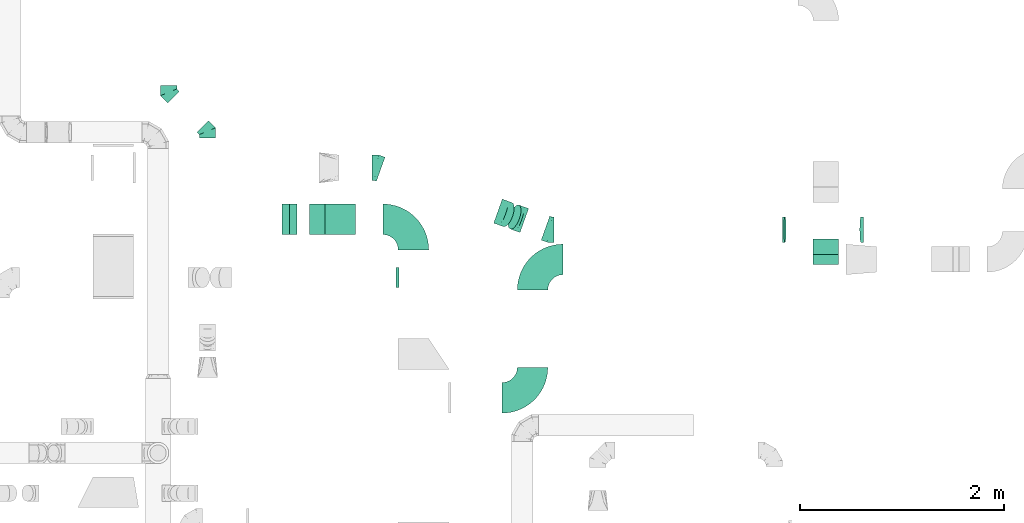
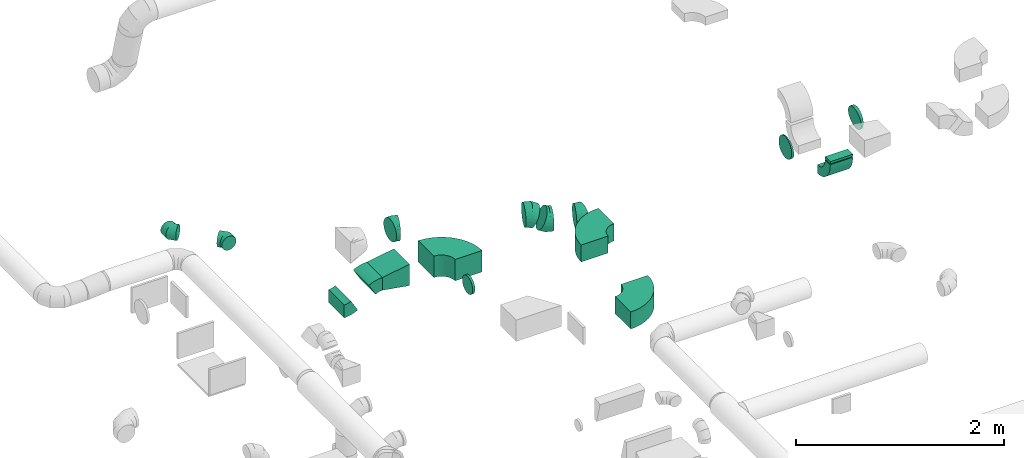
# One storey, part 46 of 62: 17 flow fittings.
"""IFC2X3 building model written with IfcOpenShell, lengths in millimetres."""

from ifc_helpers import new_model, entity, si_unit, converted_unit, derived_unit, direction, frame, frame_2d, origin, origin_2d_with_axis, place, context, subcontext, project, spatial, polyline, circle_curve, parameter, trimmed, segment, composite_curve, rectangle, outline, extrude, faceted_brep, source, transform, mapped, material, type_object, type_shapes, element, save


model = new_model("IFC2X3")

# Units and contexts
model_context = context("Model", 3, precision=0.01, world=origin(), true_north=direction((6.12303176911189e-17, 1.0)))
body_context = subcontext(model_context, "Body", "Model", "MODEL_VIEW")
ifc_project = project(units=[si_unit("LENGTHUNIT", "METRE", prefix="MILLI"), si_unit("AREAUNIT", "SQUARE_METRE"), si_unit("VOLUMEUNIT", "CUBIC_METRE"), converted_unit("PLANEANGLEUNIT", "DEGREE", entity("IfcRatioMeasure", 0.0174532925199433), si_unit("PLANEANGLEUNIT", "RADIAN"), dimensions=[0, 0, 0, 0, 0, 0, 0]), si_unit("MASSUNIT", "GRAM", prefix="KILO"), derived_unit("MASSDENSITYUNIT", [(si_unit("MASSUNIT", "GRAM", prefix="KILO"), 1), (si_unit("LENGTHUNIT", "METRE"), -3)]), derived_unit("MOMENTOFINERTIAUNIT", [(si_unit("LENGTHUNIT", "METRE"), 4)]), si_unit("TIMEUNIT", "SECOND"), si_unit("FREQUENCYUNIT", "HERTZ"), si_unit("THERMODYNAMICTEMPERATUREUNIT", "DEGREE_CELSIUS"), derived_unit("THERMALTRANSMITTANCEUNIT", [(si_unit("MASSUNIT", "GRAM", prefix="KILO"), 1), (si_unit("THERMODYNAMICTEMPERATUREUNIT", "KELVIN"), -1), (si_unit("TIMEUNIT", "SECOND"), -3)]), derived_unit("VOLUMETRICFLOWRATEUNIT", [(si_unit("LENGTHUNIT", "METRE"), 3), (si_unit("TIMEUNIT", "SECOND"), -1)]), derived_unit("MASSFLOWRATEUNIT", [(si_unit("MASSUNIT", "GRAM", prefix="KILO"), 1), (si_unit("TIMEUNIT", "SECOND"), -1)]), derived_unit("ROTATIONALFREQUENCYUNIT", [(si_unit("TIMEUNIT", "SECOND"), -1)]), si_unit("ELECTRICCURRENTUNIT", "AMPERE"), si_unit("ELECTRICVOLTAGEUNIT", "VOLT"), si_unit("POWERUNIT", "WATT"), si_unit("FORCEUNIT", "NEWTON", prefix="KILO"), si_unit("ILLUMINANCEUNIT", "LUX"), si_unit("LUMINOUSFLUXUNIT", "LUMEN"), si_unit("LUMINOUSINTENSITYUNIT", "CANDELA"), derived_unit("USERDEFINED", [(si_unit("MASSUNIT", "GRAM", prefix="KILO"), -1), (si_unit("LENGTHUNIT", "METRE"), -2), (si_unit("TIMEUNIT", "SECOND"), 3), (si_unit("LUMINOUSFLUXUNIT", "LUMEN"), 1)]), derived_unit("LINEARVELOCITYUNIT", [(si_unit("LENGTHUNIT", "METRE"), 1), (si_unit("TIMEUNIT", "SECOND"), -1)]), si_unit("PRESSUREUNIT", "PASCAL"), derived_unit("USERDEFINED", [(si_unit("LENGTHUNIT", "METRE"), -2), (si_unit("MASSUNIT", "GRAM", prefix="KILO"), 1), (si_unit("TIMEUNIT", "SECOND"), -2)]), derived_unit("LINEARFORCEUNIT", [(si_unit("MASSUNIT", "GRAM", prefix="KILO"), 1), (si_unit("LENGTHUNIT", "METRE"), 1), (si_unit("TIMEUNIT", "SECOND"), -2), (si_unit("LENGTHUNIT", "METRE"), -1)]), derived_unit("PLANARFORCEUNIT", [(si_unit("MASSUNIT", "GRAM", prefix="KILO"), 1), (si_unit("LENGTHUNIT", "METRE"), 1), (si_unit("TIMEUNIT", "SECOND"), -2), (si_unit("LENGTHUNIT", "METRE"), -2)])], contexts=[model_context])

# Site, building, storey
site_placement = place(None, origin())
site = spatial("IfcSite", under=ifc_project, at=site_placement, CompositionType="ELEMENT")
building_placement = place(site_placement, origin())
building = spatial("IfcBuilding", under=site, at=building_placement, CompositionType="ELEMENT")
storey_placement = place(building_placement, frame((0.0, 0.0, 24000.0)))
storey = spatial("IfcBuildingStorey", under=building, at=storey_placement, CompositionType="ELEMENT", Elevation=24000.0)

# Flow fittings
ifc_material = material()
duct_fitting_type_1 = type_object("IfcDuctFittingType", PredefinedType="NOTDEFINED", material=ifc_material)
shared_shape_1 = source(origin(), body_context, "Body", "SweptSolid", [
    extrude(rectangle(XDim=250.0, YDim=26.096, at=origin_2d_with_axis()), frame((6.95, 0.0, -50.0), z_axis=(0.0, 0.0, 1.0), x_axis=(0.0, -1.0, 0.0)), (0.0, 0.0, 1.0), 100.0),
])
type_shapes(duct_fitting_type_1, [shared_shape_1])
flow_fitting_1_placement = place(storey_placement, frame((57317.89, 14212.02, 3300.0), z_axis=(0.0, -1.0, 0.0), x_axis=(0.0, 0.0, -1.0)))
element("IfcFlowFitting", 1, at=flow_fitting_1_placement, inside=storey, type_object=duct_fitting_type_1, material=ifc_material, context=body_context, shape_type="MappedRepresentation", body=[
    mapped(shared_shape_1, transform((0.0, 0.0, 0.0), scale=1.0)),
])
duct_fitting_type_2 = type_object("IfcDuctFittingType", PredefinedType="NOTDEFINED", material=ifc_material)
shared_shape_2 = source(origin(), body_context, "Body", "SweptSolid", [
    extrude(outline(polyline([(-168.51, -98.64), (135.63, -98.64), (160.29, 49.32), (-127.41, 147.96), (-168.51, -98.64)])), frame((150.0, -150.0, 0.0), z_axis=(0.0, 1.0, 0.0), x_axis=(0.986393923832128, 0.0, -0.16439898730545)), (0.0, 0.0, 1.0), 300.0),
])
type_shapes(duct_fitting_type_2, [shared_shape_2])
flow_fitting_2_placement = place(storey_placement, frame((52695.91, 14606.21, 3375.0), z_axis=(0.0, 0.0, 1.0), x_axis=(-1.0, 0.0, 0.0)))
element("IfcFlowFitting", 2, at=flow_fitting_2_placement, inside=storey, type_object=duct_fitting_type_2, material=ifc_material, context=body_context, shape_type="MappedRepresentation", body=[
    mapped(shared_shape_2, transform((0.0, 0.0, 0.0), scale=1.0)),
])
duct_fitting_type_3 = type_object("IfcDuctFittingType", PredefinedType="NOTDEFINED", material=ifc_material)
shared_shape_3 = source(origin(), body_context, "Body", "Brep", [
    faceted_brep([(-66.27, 0.0, -80.0), (-66.27, -20.71, -77.27), (-66.27, -40.0, -69.28), (-66.27, -56.57, -56.57), (-66.27, -69.28, -40.0), (-66.27, -77.27, -20.71), (-66.27, -80.0, 0.0), (-66.27, -77.27, 20.71), (-66.27, -69.28, 40.0), (-66.27, -56.57, 56.57), (-66.27, -40.0, 69.28), (-66.27, -20.71, 77.27), (-66.27, 0.0, 80.0), (-66.27, 20.71, 77.27), (-66.27, 40.0, 69.28), (-66.27, 56.57, 56.57), (-66.27, 69.28, 40.0), (-66.27, 77.27, 20.71), (-66.27, 80.0, 0.0), (-66.27, 77.27, -20.71), (-66.27, 69.28, -40.0), (-66.27, 56.57, -56.57), (-66.27, 40.0, -69.28), (-66.27, 20.71, -77.27), (-8.58, 20.71, 77.27), (-16.57, 40.0, 69.28), (0.0, 0.0, 80.0), (-23.43, 56.57, 56.57), (-28.7, 69.28, 40.0), (-32.01, 77.27, 20.71), (-33.14, 80.0, 0.0), (-32.01, 77.27, -20.71), (-28.7, 69.28, -40.0), (-23.43, 56.57, -56.57), (-8.58, 20.71, -77.27), (0.0, 0.0, -80.0), (-16.57, 40.0, -69.28), (8.58, -20.71, -77.27), (16.57, -40.0, -69.28), (23.43, -56.57, -56.57), (28.7, -69.28, -40.0), (32.01, -77.27, -20.71), (33.14, -80.0, 0.0), (32.01, -77.27, 20.71), (28.7, -69.28, 40.0), (23.43, -56.57, 56.57), (16.57, -40.0, 69.28), (8.58, -20.71, 77.27), (46.86, 46.86, 80.0), (32.22, 61.5, 77.27), (18.58, 75.15, 69.28), (6.86, 86.86, 56.57), (-2.13, 95.85, 40.0), (-7.78, 101.5, 20.71), (-9.71, 103.43, 0.0), (-7.78, 101.5, -20.71), (-2.13, 95.85, -40.0), (6.86, 86.86, -56.57), (18.58, 75.15, -69.28), (32.22, 61.5, -77.27), (46.86, 46.86, -80.0), (61.5, 32.22, -77.27), (75.15, 18.58, -69.28), (86.86, 6.86, -56.57), (95.85, -2.13, -40.0), (101.5, -7.78, -20.71), (103.43, -9.71, 0.0), (101.5, -7.78, 20.71), (95.85, -2.13, 40.0), (86.86, 6.86, 56.57), (75.15, 18.58, 69.28), (61.5, 32.22, 77.27)], [[[0, 1, 2, 3, 4, 5, 6, 7, 8, 9, 10, 11, 12, 13, 14, 15, 16, 17, 18, 19, 20, 21, 22, 23]], [[24, 25, 14, 13]], [[26, 24, 13, 12]], [[14, 25, 27, 15]], [[28, 29, 17, 16]], [[28, 16, 15, 27]], [[30, 18, 17, 29]], [[31, 32, 20, 19]], [[30, 31, 19, 18]], [[32, 33, 21, 20]], [[34, 35, 0, 23]], [[36, 34, 23, 22]], [[33, 36, 22, 21]], [[1, 0, 35, 37]], [[2, 1, 37, 38]], [[38, 39, 3, 2]], [[5, 4, 40, 41]], [[6, 5, 41, 42]], [[39, 40, 4, 3]], [[6, 42, 43, 7]], [[7, 43, 44, 8]], [[8, 44, 45, 9]], [[9, 45, 46, 10]], [[10, 46, 47, 11]], [[26, 12, 11, 47]], [[24, 26, 48, 49]], [[25, 24, 49, 50]], [[27, 25, 50, 51]], [[29, 28, 52, 53]], [[30, 29, 53, 54]], [[51, 52, 28, 27]], [[30, 54, 55, 31]], [[31, 55, 56, 32]], [[57, 33, 32, 56]], [[36, 58, 59, 34]], [[34, 59, 60, 35]], [[58, 36, 33, 57]], [[35, 60, 61, 37]], [[37, 61, 62, 38]], [[63, 39, 38, 62]], [[40, 64, 65, 41]], [[41, 65, 66, 42]], [[64, 40, 39, 63]], [[43, 42, 66, 67]], [[44, 43, 67, 68]], [[68, 69, 45, 44]], [[47, 46, 70, 71]], [[26, 47, 71, 48]], [[69, 70, 46, 45]], [[59, 58, 57, 56, 55, 54, 53, 52, 51, 50, 49, 48, 71, 70, 69, 68, 67, 66, 65, 64, 63, 62, 61, 60]]]),
])
type_shapes(duct_fitting_type_3, [shared_shape_3])
for number, where, z_axis, x_axis in (
    (3, (50861.07, 15854.24, 3680.0), (0.0, 0.0, 1.0), (0.0, -1.0, 0.0)),
    (4, (51242.9, 15472.41, 3680.0), (0.0, 0.0, 1.0), (0.0, 1.0, 0.0)),
):
    element("IfcFlowFitting", number, at=place(storey_placement, frame(where, z_axis=z_axis, x_axis=x_axis)), inside=storey, type_object=duct_fitting_type_3, material=ifc_material, context=body_context, shape_type="MappedRepresentation", body=[
        mapped(shared_shape_3, transform((0.0, 0.0, 0.0), scale=1.0)),
    ])
duct_fitting_type_4 = type_object("IfcDuctFittingType", PredefinedType="NOTDEFINED", material=ifc_material)
shared_shape_4 = source(origin(), body_context, "Body", "Brep", [
    faceted_brep([(20.0, 0.0, -100.0), (20.0, 25.88, -96.59), (20.0, 50.0, -86.6), (20.0, 70.71, -70.71), (20.0, 86.6, -50.0), (20.0, 96.59, -25.88), (20.0, 100.0, 0.0), (20.0, 96.59, 25.88), (20.0, 86.6, 50.0), (20.0, 70.71, 70.71), (20.0, 50.0, 86.6), (20.0, 25.88, 96.59), (20.0, 0.0, 100.0), (20.0, -25.88, 96.59), (20.0, -50.0, 86.6), (20.0, -70.71, 70.71), (20.0, -86.6, 50.0), (20.0, -96.59, 25.88), (20.0, -100.0, 0.0), (20.0, -96.59, -25.88), (20.0, -86.6, -50.0), (20.0, -70.71, -70.71), (20.0, -50.0, -86.6), (20.0, -25.88, -96.59), (0.0, 0.0, 100.0), (-6.1, 0.0, 100.0), (-6.1, -25.88, 96.59), (0.0, -25.88, 96.59), (-6.1, -50.0, 86.6), (0.0, -50.0, 86.6), (0.0, -70.71, 70.71), (-6.1, -70.71, 70.71), (0.0, -86.6, 50.0), (-6.1, -86.6, 50.0), (-6.1, -96.59, 25.88), (0.0, -96.59, 25.88), (-6.1, -100.0, 0.0), (0.0, -100.0, 0.0), (-6.1, -96.59, -25.88), (0.0, -96.59, -25.88), (-6.1, -86.6, -50.0), (0.0, -86.6, -50.0), (0.0, -70.71, -70.71), (-6.1, -70.71, -70.71), (0.0, -50.0, -86.6), (-6.1, -50.0, -86.6), (-6.1, -25.88, -96.59), (0.0, -25.88, -96.59), (-6.1, 0.0, -100.0), (0.0, 0.0, -100.0), (-6.1, 25.88, -96.59), (0.0, 25.88, -96.59), (-6.1, 50.0, -86.6), (0.0, 50.0, -86.6), (0.0, 70.71, -70.71), (-6.1, 70.71, -70.71), (0.0, 86.6, -50.0), (-6.1, 86.6, -50.0), (-6.1, 96.59, -25.88), (0.0, 96.59, -25.88), (-6.1, 100.0, 0.0), (0.0, 100.0, 0.0), (-6.1, 96.59, 25.88), (0.0, 96.59, 25.88), (-6.1, 86.6, 50.0), (0.0, 86.6, 50.0), (0.0, 70.71, 70.71), (-6.1, 70.71, 70.71), (0.0, 50.0, 86.6), (-6.1, 50.0, 86.6), (-6.1, 25.88, 96.59), (0.0, 25.88, 96.59)], [[[0, 1, 2, 3, 4, 5, 6, 7, 8, 9, 10, 11, 12, 13, 14, 15, 16, 17, 18, 19, 20, 21, 22, 23]], [[13, 12, 24, 25, 26, 27]], [[14, 13, 27, 26, 28, 29]], [[30, 15, 14, 29, 28, 31]], [[17, 16, 32, 33, 34, 35]], [[18, 17, 35, 34, 36, 37]], [[32, 16, 15, 30, 31, 33]], [[19, 18, 37, 36, 38, 39]], [[20, 19, 39, 38, 40, 41]], [[42, 21, 20, 41, 40, 43]], [[23, 22, 44, 45, 46, 47]], [[0, 23, 47, 46, 48, 49]], [[44, 22, 21, 42, 43, 45]], [[1, 0, 49, 48, 50, 51]], [[2, 1, 51, 50, 52, 53]], [[54, 3, 2, 53, 52, 55]], [[5, 4, 56, 57, 58, 59]], [[6, 5, 59, 58, 60, 61]], [[56, 4, 3, 54, 55, 57]], [[7, 6, 61, 60, 62, 63]], [[8, 7, 63, 62, 64, 65]], [[66, 9, 8, 65, 64, 67]], [[11, 10, 68, 69, 70, 71]], [[12, 11, 71, 70, 25, 24]], [[68, 10, 9, 66, 67, 69]], [[46, 45, 43, 40, 38, 36, 34, 33, 31, 28, 26, 25, 70, 69, 67, 64, 62, 60, 58, 57, 55, 52, 50, 48]]]),
])
type_shapes(duct_fitting_type_4, [shared_shape_4])
flow_fitting_3_placement = place(storey_placement, frame((53115.82, 14034.27, 3375.0), z_axis=(0.0, 0.0, -1.0), x_axis=(-1.0, 0.0, 0.0)))
element("IfcFlowFitting", 5, at=flow_fitting_3_placement, inside=storey, type_object=duct_fitting_type_4, material=ifc_material, context=body_context, shape_type="MappedRepresentation", body=[
    mapped(shared_shape_4, transform((0.0, 0.0, 0.0), scale=1.0)),
])
duct_fitting_type_5 = type_object("IfcDuctFittingType", PredefinedType="NOTDEFINED", material=ifc_material)
shared_shape_5 = source(origin(), body_context, "Body", "Brep", [
    faceted_brep([(-43.32, 0.0, -125.0), (-43.32, -32.35, -120.74), (-43.32, -62.5, -108.25), (-43.32, -88.39, -88.39), (-43.32, -108.25, -62.5), (-43.32, -120.74, -32.35), (-43.32, -125.0, 0.0), (-43.32, -120.74, 32.35), (-43.32, -108.25, 62.5), (-43.32, -88.39, 88.39), (-43.32, -62.5, 108.25), (-43.32, -32.35, 120.74), (-43.32, 0.0, 125.0), (-43.32, 32.35, 120.74), (-43.32, 62.5, 108.25), (-43.32, 88.39, 88.39), (-43.32, 108.25, 62.5), (-43.32, 120.74, 32.35), (-43.32, 125.0, 0.0), (-43.32, 120.74, -32.35), (-43.32, 108.25, -62.5), (-43.32, 88.39, -88.39), (-43.32, 62.5, -108.25), (-43.32, 32.35, -120.74), (-5.61, 32.35, 120.74), (-10.83, 62.5, 108.25), (0.0, 0.0, 125.0), (-15.32, 88.39, 88.39), (-20.92, 120.74, 32.35), (-21.66, 125.0, 0.0), (-18.76, 108.25, 62.5), (-18.76, 108.25, -62.5), (-15.32, 88.39, -88.39), (-20.92, 120.74, -32.35), (-5.61, 32.35, -120.74), (0.0, 0.0, -125.0), (-10.83, 62.5, -108.25), (5.61, -32.35, -120.74), (10.83, -62.5, -108.25), (15.32, -88.39, -88.39), (18.76, -108.25, -62.5), (20.92, -120.74, -32.35), (21.66, -125.0, 0.0), (20.92, -120.74, 32.35), (18.76, -108.25, 62.5), (15.32, -88.39, 88.39), (10.83, -62.5, 108.25), (5.61, -32.35, 120.74), (40.79, 14.58, 125.0), (29.91, 45.04, 120.74), (19.77, 73.43, 108.25), (11.06, 97.81, 88.39), (4.37, 116.52, 62.5), (0.17, 128.28, 32.35), (-1.26, 132.29, 0.0), (0.17, 128.28, -32.35), (4.37, 116.52, -62.5), (11.06, 97.81, -88.39), (19.77, 73.43, -108.25), (29.91, 45.04, -120.74), (40.79, 14.58, -125.0), (51.68, -15.89, -120.74), (61.82, -44.28, -108.25), (70.53, -68.66, -88.39), (77.22, -87.37, -62.5), (81.42, -99.13, -32.35), (82.85, -103.14, 0.0), (81.42, -99.13, 32.35), (77.22, -87.37, 62.5), (70.53, -68.66, 88.39), (61.82, -44.28, 108.25), (51.68, -15.89, 120.74)], [[[0, 1, 2, 3, 4, 5, 6, 7, 8, 9, 10, 11, 12, 13, 14, 15, 16, 17, 18, 19, 20, 21, 22, 23]], [[24, 25, 14, 13]], [[26, 24, 13, 12]], [[14, 25, 27, 15]], [[28, 29, 18, 17]], [[30, 28, 17, 16]], [[15, 27, 30, 16]], [[20, 31, 32, 21]], [[33, 31, 20, 19]], [[18, 29, 33, 19]], [[34, 35, 0, 23]], [[36, 34, 23, 22]], [[32, 36, 22, 21]], [[2, 1, 37, 38]], [[3, 2, 38, 39]], [[0, 35, 37, 1]], [[5, 4, 40, 41]], [[6, 5, 41, 42]], [[3, 39, 40, 4]], [[6, 42, 43, 7]], [[7, 43, 44, 8]], [[8, 44, 45, 9]], [[10, 46, 47, 11]], [[11, 47, 26, 12]], [[10, 9, 45, 46]], [[24, 26, 48, 49]], [[25, 24, 49, 50]], [[27, 25, 50, 51]], [[28, 30, 52, 53]], [[29, 28, 53, 54]], [[27, 51, 52, 30]], [[29, 54, 55, 33]], [[33, 55, 56, 31]], [[31, 56, 57, 32]], [[36, 58, 59, 34]], [[34, 59, 60, 35]], [[36, 32, 57, 58]], [[35, 60, 61, 37]], [[37, 61, 62, 38]], [[38, 62, 63, 39]], [[40, 64, 65, 41]], [[41, 65, 66, 42]], [[39, 63, 64, 40]], [[43, 42, 66, 67]], [[44, 43, 67, 68]], [[45, 44, 68, 69]], [[47, 46, 70, 71]], [[26, 47, 71, 48]], [[69, 70, 46, 45]], [[59, 58, 57, 56, 55, 54, 53, 52, 51, 50, 49, 48, 71, 70, 69, 68, 67, 66, 65, 64, 63, 62, 61, 60]]]),
])
type_shapes(duct_fitting_type_5, [shared_shape_5])
for number, where, z_axis, x_axis in (
    (6, (54603.55, 14505.3, 3375.0), (0.0, 0.0, 1.0), (0.941697054037879, -0.336461971723967, 0.0)),
    (7, (52903.13, 15112.85, 3450.0), (0.0, 0.0, 1.0), (-0.941697054037876, 0.336461971723975, 0.0)),
):
    element("IfcFlowFitting", number, at=place(storey_placement, frame(where, z_axis=z_axis, x_axis=x_axis)), inside=storey, type_object=duct_fitting_type_5, material=ifc_material, context=body_context, shape_type="MappedRepresentation", body=[
        mapped(shared_shape_5, transform((0.0, 0.0, 0.0), scale=1.0)),
    ])
duct_fitting_type_6 = type_object("IfcDuctFittingType", PredefinedType="NOTDEFINED", material=ifc_material)
shared_shape_6 = source(origin(), body_context, "Body", "Brep", [
    faceted_brep([(-53.18, 0.0, -125.0), (-53.18, -32.35, -120.74), (-53.18, -62.5, -108.25), (-53.18, -88.39, -88.39), (-53.18, -108.25, -62.5), (-53.18, -120.74, -32.35), (-53.18, -125.0, 0.0), (-53.18, -120.74, 32.35), (-53.18, -108.25, 62.5), (-53.18, -88.39, 88.39), (-53.18, -62.5, 108.25), (-53.18, -32.35, 120.74), (-53.18, 0.0, 125.0), (-53.18, 32.35, 120.74), (-53.18, 62.5, 108.25), (-53.18, 88.39, 88.39), (-53.18, 108.25, 62.5), (-53.18, 120.74, 32.35), (-53.18, 125.0, 0.0), (-53.18, 120.74, -32.35), (-53.18, 108.25, -62.5), (-53.18, 88.39, -88.39), (-53.18, 62.5, -108.25), (-53.18, 32.35, -120.74), (-6.88, 32.35, 120.74), (-13.29, 62.5, 108.25), (0.0, 0.0, 125.0), (-18.8, 88.39, 88.39), (-25.68, 120.74, 32.35), (-26.59, 125.0, 0.0), (-23.03, 108.25, 62.5), (-23.03, 108.25, -62.5), (-18.8, 88.39, -88.39), (-25.68, 120.74, -32.35), (-6.88, 32.35, -120.74), (0.0, 0.0, -125.0), (-13.29, 62.5, -108.25), (6.88, -32.35, -120.74), (13.29, -62.5, -108.25), (18.8, -88.39, -88.39), (23.03, -108.25, -62.5), (25.68, -120.74, -32.35), (26.59, -125.0, 0.0), (25.68, -120.74, 32.35), (23.03, -108.25, 62.5), (18.8, -88.39, 88.39), (13.29, -62.5, 108.25), (6.88, -32.35, 120.74), (48.57, 21.64, 125.0), (35.41, 51.19, 120.74), (23.14, 78.73, 108.25), (12.6, 102.38, 88.39), (4.51, 120.52, 62.5), (-0.57, 131.93, 32.35), (-2.3, 135.82, 0.0), (-0.57, 131.93, -32.35), (4.51, 120.52, -62.5), (12.6, 102.38, -88.39), (23.14, 78.73, -108.25), (35.41, 51.19, -120.74), (48.57, 21.64, -125.0), (61.74, -7.91, -120.74), (74.01, -35.45, -108.25), (84.55, -59.09, -88.39), (92.63, -77.24, -62.5), (97.72, -88.64, -32.35), (99.45, -92.54, 0.0), (97.72, -88.64, 32.35), (92.63, -77.24, 62.5), (84.55, -59.09, 88.39), (74.01, -35.45, 108.25), (61.74, -7.91, 120.74)], [[[0, 1, 2, 3, 4, 5, 6, 7, 8, 9, 10, 11, 12, 13, 14, 15, 16, 17, 18, 19, 20, 21, 22, 23]], [[24, 25, 14, 13]], [[26, 24, 13, 12]], [[14, 25, 27, 15]], [[28, 29, 18, 17]], [[30, 28, 17, 16]], [[15, 27, 30, 16]], [[20, 31, 32, 21]], [[33, 31, 20, 19]], [[18, 29, 33, 19]], [[34, 35, 0, 23]], [[36, 34, 23, 22]], [[32, 36, 22, 21]], [[1, 0, 35, 37]], [[2, 1, 37, 38]], [[3, 2, 38, 39]], [[5, 4, 40, 41]], [[6, 5, 41, 42]], [[39, 40, 4, 3]], [[6, 42, 43, 7]], [[7, 43, 44, 8]], [[8, 44, 45, 9]], [[9, 45, 46, 10]], [[10, 46, 47, 11]], [[26, 12, 11, 47]], [[24, 26, 48, 49]], [[25, 24, 49, 50]], [[27, 25, 50, 51]], [[28, 30, 52, 53]], [[29, 28, 53, 54]], [[27, 51, 52, 30]], [[29, 54, 55, 33]], [[33, 55, 56, 31]], [[31, 56, 57, 32]], [[36, 58, 59, 34]], [[34, 59, 60, 35]], [[36, 32, 57, 58]], [[61, 62, 38, 37]], [[60, 61, 37, 35]], [[63, 39, 38, 62]], [[40, 64, 65, 41]], [[41, 65, 66, 42]], [[64, 40, 39, 63]], [[67, 68, 44, 43]], [[66, 67, 43, 42]], [[68, 69, 45, 44]], [[47, 46, 70, 71]], [[26, 47, 71, 48]], [[69, 70, 46, 45]], [[59, 58, 57, 56, 55, 54, 53, 52, 51, 50, 49, 48, 71, 70, 69, 68, 67, 66, 65, 64, 63, 62, 61, 60]]]),
])
type_shapes(duct_fitting_type_6, [shared_shape_6])
for number, where, z_axis, x_axis in (
    (8, (54304.47, 14612.16, 3375.0), (0.33646197172399, 0.941697054037871, 0.0), (-0.941697054037871, 0.33646197172399, 0.0)),
    (9, (54145.96, 14668.79, 3450.0), (-0.336461971723975, -0.941697054037876, 0.0), (-0.860171315661179, 0.307333378231116, 0.407003074114639)),
):
    element("IfcFlowFitting", number, at=place(storey_placement, frame(where, z_axis=z_axis, x_axis=x_axis)), inside=storey, type_object=duct_fitting_type_6, material=ifc_material, context=body_context, shape_type="MappedRepresentation", body=[
        mapped(shared_shape_6, transform((0.0, 0.0, 0.0), scale=1.0)),
    ])
duct_fitting_type_7 = type_object("IfcDuctFittingType", PredefinedType="NOTDEFINED", material=ifc_material)
shared_shape_7 = source(origin(), body_context, "Body", "Brep", [
    faceted_brep([(-12.14, 0.0, -125.0), (-12.14, -32.35, -120.74), (-12.14, -62.5, -108.25), (-12.14, -88.39, -88.39), (-12.14, -108.25, -62.5), (-12.14, -120.74, -32.35), (-12.14, -125.0, 0.0), (-12.14, -120.74, 32.35), (-12.14, -108.25, 62.5), (-12.14, -88.39, 88.39), (-12.14, -62.5, 108.25), (-12.14, -32.35, 120.74), (-12.14, 0.0, 125.0), (-12.14, 32.35, 120.74), (-12.14, 62.5, 108.25), (-12.14, 88.39, 88.39), (-12.14, 108.25, 62.5), (-12.14, 120.74, 32.35), (-12.14, 125.0, 0.0), (-12.14, 120.74, -32.35), (-12.14, 108.25, -62.5), (-12.14, 88.39, -88.39), (-12.14, 62.5, -108.25), (-12.14, 32.35, -120.74), (-1.57, 32.35, 120.74), (-3.03, 62.5, 108.25), (0.0, 0.0, 125.0), (-4.29, 88.39, 88.39), (-5.86, 120.74, 32.35), (-6.07, 125.0, 0.0), (-5.26, 108.25, 62.5), (-5.26, 108.25, -62.5), (-4.29, 88.39, -88.39), (-5.86, 120.74, -32.35), (-1.57, 32.35, -120.74), (0.0, 0.0, -125.0), (-3.03, 62.5, -108.25), (1.57, -32.35, -120.74), (3.03, -62.5, -108.25), (4.29, -88.39, -88.39), (5.26, -108.25, -62.5), (5.86, -120.74, -32.35), (6.07, -125.0, 0.0), (5.86, -120.74, 32.35), (5.26, -108.25, 62.5), (4.29, -88.39, 88.39), (3.03, -62.5, 108.25), (1.57, -32.35, 120.74), (12.08, 1.18, 125.0), (8.95, 33.38, 120.74), (6.03, 63.38, 108.25), (3.52, 89.15, 88.39), (1.59, 108.92, 62.5), (0.38, 121.35, 32.35), (-0.03, 125.59, 0.0), (0.38, 121.35, -32.35), (1.59, 108.92, -62.5), (3.52, 89.15, -88.39), (6.03, 63.38, -108.25), (8.95, 33.38, -120.74), (12.08, 1.18, -125.0), (15.22, -31.02, -120.74), (18.14, -61.03, -108.25), (20.65, -86.8, -88.39), (22.57, -106.57, -62.5), (23.78, -119.0, -32.35), (24.19, -123.24, 0.0), (23.78, -119.0, 32.35), (22.57, -106.57, 62.5), (20.65, -86.8, 88.39), (18.14, -61.03, 108.25), (15.22, -31.02, 120.74)], [[[0, 1, 2, 3, 4, 5, 6, 7, 8, 9, 10, 11, 12, 13, 14, 15, 16, 17, 18, 19, 20, 21, 22, 23]], [[24, 25, 14, 13]], [[26, 24, 13, 12]], [[14, 25, 27, 15]], [[28, 29, 18, 17]], [[30, 28, 17, 16]], [[15, 27, 30, 16]], [[20, 31, 32, 21]], [[33, 31, 20, 19]], [[18, 29, 33, 19]], [[34, 35, 0, 23]], [[36, 34, 23, 22]], [[32, 36, 22, 21]], [[2, 1, 37, 38]], [[3, 2, 38, 39]], [[0, 35, 37, 1]], [[5, 4, 40, 41]], [[6, 5, 41, 42]], [[39, 40, 4, 3]], [[6, 42, 43, 7]], [[7, 43, 44, 8]], [[8, 44, 45, 9]], [[10, 46, 47, 11]], [[11, 47, 26, 12]], [[9, 45, 46, 10]], [[24, 26, 48, 49]], [[25, 24, 49, 50]], [[27, 25, 50, 51]], [[28, 30, 52, 53]], [[29, 28, 53, 54]], [[27, 51, 52, 30]], [[29, 54, 55, 33]], [[33, 55, 56, 31]], [[31, 56, 57, 32]], [[36, 58, 59, 34]], [[34, 59, 60, 35]], [[36, 32, 57, 58]], [[35, 60, 61, 37]], [[37, 61, 62, 38]], [[38, 62, 63, 39]], [[40, 64, 65, 41]], [[41, 65, 66, 42]], [[39, 63, 64, 40]], [[43, 42, 66, 67]], [[44, 43, 67, 68]], [[45, 44, 68, 69]], [[47, 46, 70, 71]], [[26, 47, 71, 48]], [[69, 70, 46, 45]], [[59, 58, 57, 56, 55, 54, 53, 52, 51, 50, 49, 48, 71, 70, 69, 68, 67, 66, 65, 64, 63, 62, 61, 60]]]),
])
type_shapes(duct_fitting_type_7, [shared_shape_7])
for number, where, z_axis, x_axis in (
    (10, (56903.55, 14505.3, 3375.0), (0.0, -1.0, 0.0), (1.0, 0.0, 0.0)),
    (11, (57673.99, 14505.3, 3450.0), (0.0, -1.0, 0.0), (-1.0, 0.0, 0.0)),
):
    element("IfcFlowFitting", number, at=place(storey_placement, frame(where, z_axis=z_axis, x_axis=x_axis)), inside=storey, type_object=duct_fitting_type_7, material=ifc_material, context=body_context, shape_type="MappedRepresentation", body=[
        mapped(shared_shape_7, transform((0.0, 0.0, 0.0), scale=1.0)),
    ])
duct_fitting_type_8 = type_object("IfcDuctFittingType", PredefinedType="NOTDEFINED", material=ifc_material)
shared_shape_8 = source(origin(), body_context, "Body", "SweptSolid", [
    extrude(outline(composite_curve([segment(polyline([(-300.0, -150.0), (0.0, -150.0)]), True, "CONTINUOUS"), segment(trimmed(circle_curve(frame_2d((150.0, -150.0), x_axis=(0.0, 1.0)), 150.0), [parameter(0.0)], [parameter(90.0)], True, "PARAMETER"), False, "CONTINUOUS"), segment(polyline([(150.0, 0.0), (150.0, 300.0)]), True, "CONTINUOUS"), segment(trimmed(circle_curve(frame_2d((150.0, -150.0), x_axis=(0.0, 1.0)), 450.0), [parameter(0.0)], [parameter(90.0000000000001)], True, "PARAMETER"), True, "CONTINUOUS")], self_intersect=False)), frame((-150.0, 150.0, -125.0), z_axis=(0.0, 0.0, 1.0), x_axis=(-1.0, 0.0, 0.0)), (0.0, 0.0, 1.0), 250.0),
])
type_shapes(duct_fitting_type_8, [shared_shape_8])
flow_fitting_4_placement = place(storey_placement, frame((53265.82, 14606.21, 3375.0), z_axis=(0.0, 0.0, 1.0), x_axis=(0.0, 1.0, 0.0)))
element("IfcFlowFitting", 12, at=flow_fitting_4_placement, inside=storey, type_object=duct_fitting_type_8, material=ifc_material, context=body_context, shape_type="MappedRepresentation", body=[
    mapped(shared_shape_8, transform((0.0, 0.0, 0.0), scale=1.0)),
])
duct_fitting_type_9 = type_object("IfcDuctFittingType", PredefinedType="NOTDEFINED", material=ifc_material)
shared_shape_9 = source(origin(), body_context, "Body", "SweptSolid", [
    extrude(outline(composite_curve([segment(polyline([(-300.0, -150.0), (0.0, -150.0)]), True, "CONTINUOUS"), segment(trimmed(circle_curve(frame_2d((150.0, -150.0), x_axis=(0.0, 1.0)), 150.0), [parameter(0.0)], [parameter(90.0)], True, "PARAMETER"), False, "CONTINUOUS"), segment(polyline([(150.0, 0.0), (150.0, 300.0)]), True, "CONTINUOUS"), segment(trimmed(circle_curve(frame_2d((150.0, -150.0), x_axis=(0.0, 1.0)), 450.0), [parameter(0.0)], [parameter(90.0000000000001)], True, "PARAMETER"), True, "CONTINUOUS")], self_intersect=False)), frame((-150.0, 150.0, -100.0), z_axis=(0.0, 0.0, 1.0), x_axis=(-1.0, 0.0, 0.0)), (0.0, 0.0, 1.0), 200.0),
])
type_shapes(duct_fitting_type_9, [shared_shape_9])
flow_fitting_5_placement = place(storey_placement, frame((54435.82, 12852.02, 3400.0)))
element("IfcFlowFitting", 13, at=flow_fitting_5_placement, inside=storey, type_object=duct_fitting_type_9, material=ifc_material, context=body_context, shape_type="MappedRepresentation", body=[
    mapped(shared_shape_9, transform((0.0, 0.0, 0.0), scale=1.0)),
])
flow_fitting_6_placement = place(storey_placement, frame((54435.82, 14212.02, 3400.0), z_axis=(0.0, 0.0, 1.0), x_axis=(-1.0, 0.0, 0.0)))
element("IfcFlowFitting", 14, at=flow_fitting_6_placement, inside=storey, type_object=duct_fitting_type_9, material=ifc_material, context=body_context, shape_type="MappedRepresentation", body=[
    mapped(shared_shape_9, transform((0.0, 0.0, 0.0), scale=1.0)),
])
duct_fitting_type_10 = type_object("IfcDuctFittingType", PredefinedType="NOTDEFINED", material=ifc_material)
shared_shape_10 = source(origin(), body_context, "Body", "SweptSolid", [
    extrude(outline(composite_curve([segment(polyline([(-90.07, -56.25), (59.93, -56.25)]), True, "CONTINUOUS"), segment(trimmed(circle_curve(frame_2d((209.93, -56.25), x_axis=(-0.866025410712631, 0.499999988000022)), 150.0), [parameter(0.0)], [parameter(29.9999992060879)], True, "PARAMETER"), False, "CONTINUOUS"), segment(polyline([(80.02, 18.75), (-49.88, 93.75)]), True, "CONTINUOUS"), segment(trimmed(circle_curve(frame_2d((209.93, -56.25), x_axis=(-0.866025410712631, 0.499999988000022)), 300.0), [parameter(0.0)], [parameter(29.9999992060879)], True, "PARAMETER"), True, "CONTINUOUS")], self_intersect=False)), frame((-4.04, 15.07, -150.0), z_axis=(0.0, 0.0, 1.0), x_axis=(-0.499999988000022, 0.866025410712629, 0.0)), (0.0, 0.0, 1.0), 300.0),
])
type_shapes(duct_fitting_type_10, [shared_shape_10])
for number, where, z_axis, x_axis in (
    (15, (52335.62, 14606.21, 3375.0), (0.0, -1.0, 0.0), (-1.0, 0.0, 0.0)),
    (16, (52032.51, 14606.21, 3200.0), (0.0, 1.0, 0.0), (-0.866025410712559, 0.0, -0.499999988000144)),
):
    element("IfcFlowFitting", number, at=place(storey_placement, frame(where, z_axis=z_axis, x_axis=x_axis)), inside=storey, type_object=duct_fitting_type_10, material=ifc_material, context=body_context, shape_type="MappedRepresentation", body=[
        mapped(shared_shape_10, transform((0.0, 0.0, 0.0), scale=1.0)),
    ])
duct_fitting_type_11 = type_object("IfcDuctFittingType", PredefinedType="NOTDEFINED", material=ifc_material)
shared_shape_11 = source(origin(), body_context, "Body", "SweptSolid", [
    extrude(outline(composite_curve([segment(polyline([(-150.0, -100.0), (-50.0, -100.0)]), True, "CONTINUOUS"), segment(trimmed(circle_curve(frame_2d((100.0, -100.0), x_axis=(0.0, 1.0)), 150.0), [parameter(0.0)], [parameter(90.0000000000001)], True, "PARAMETER"), False, "CONTINUOUS"), segment(polyline([(100.0, 50.0), (100.0, 150.0)]), True, "CONTINUOUS"), segment(trimmed(circle_curve(frame_2d((100.0, -100.0), x_axis=(0.0, 1.0)), 250.0), [parameter(0.0)], [parameter(90.0000000000001)], True, "PARAMETER"), True, "CONTINUOUS")], self_intersect=False)), frame((-100.0, 100.0, -125.0), z_axis=(0.0, 0.0, 1.0), x_axis=(-1.0, 0.0, 0.0)), (0.0, 0.0, 1.0), 250.0),
])
type_shapes(duct_fitting_type_11, [shared_shape_11])
flow_fitting_7_placement = place(storey_placement, frame((57317.89, 14212.02, 3070.0), z_axis=(-1.0, 0.0, 0.0), x_axis=(0.0, -1.0, 0.0)))
element("IfcFlowFitting", 17, at=flow_fitting_7_placement, inside=storey, type_object=duct_fitting_type_11, material=ifc_material, context=body_context, shape_type="MappedRepresentation", body=[
    mapped(shared_shape_11, transform((0.0, 0.0, 0.0), scale=1.0)),
])

save(model, "model.ifc")
